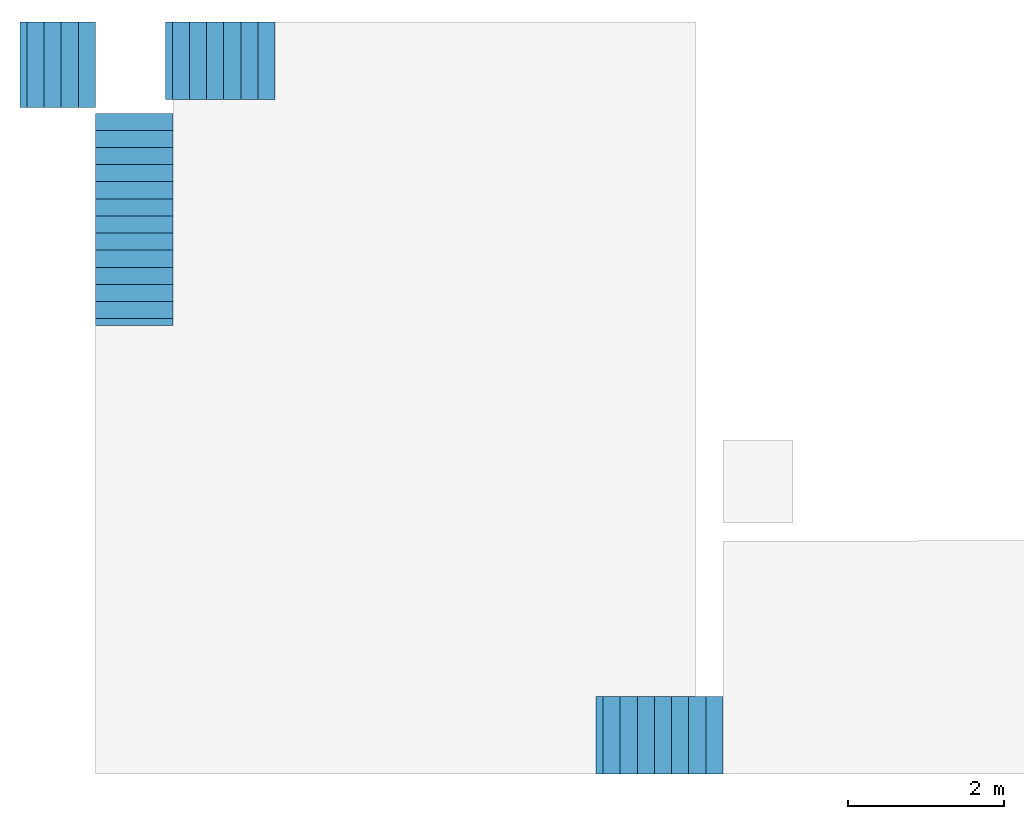
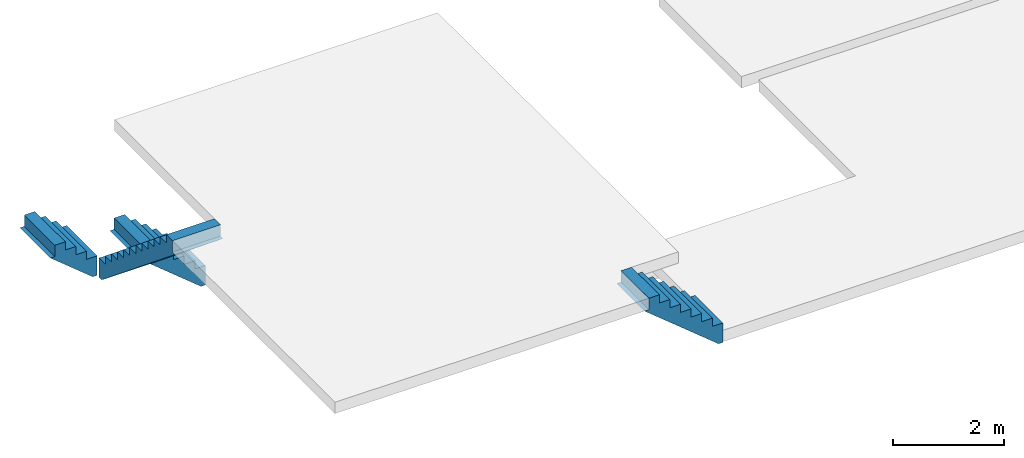
# One storey, part 2 of 2: 4 stair flights.
"""IFC4 building model written with IfcOpenShell, lengths in metres."""

from ifc_helpers import new_model, entity, si_unit, converted_unit, frame, origin_with_axes, origin_2d_with_axis, place, context, subcontext, project, spatial, polygons, type_object, element, save


model = new_model("IFC4")

# Units and contexts
model_context = context("Model", 3, precision=1e-05, world=origin_with_axes())
plan_context = context("Plan", 2, precision=1e-05, world=origin_2d_with_axis())
body_context = subcontext(model_context, "Body", "Model", "MODEL_VIEW")
ifc_project = project(units=[si_unit("VOLUMEUNIT", "CUBIC_METRE"), si_unit("LENGTHUNIT", "METRE"), converted_unit("PLANEANGLEUNIT", "degree", entity("IfcReal", 0.0174532925199433), si_unit("PLANEANGLEUNIT", "RADIAN"), dimensions=[0, 0, 0, 0, 0, 0, 0]), si_unit("AREAUNIT", "SQUARE_METRE")], contexts=[model_context, plan_context])

# Site, building, storey
site_placement = place(None, origin_with_axes())
site = spatial("IfcSite", under=ifc_project, at=site_placement)
building_placement = place(site_placement, origin_with_axes())
building = spatial("IfcBuilding", under=site, at=building_placement)
storey_placement = place(building_placement, frame((0.0, 0.0, 4.23999977111816), z_axis=(0.0, 0.0, 1.0), x_axis=(1.0, 0.0, 0.0)))
storey = spatial("IfcBuildingStorey", under=building, at=storey_placement, Name="First floor")

# Stair flights
stair_flight_type = type_object("IfcStairFlightType", Name="steps", PredefinedType="STRAIGHT")
stair_flight_1_placement = place(storey_placement, frame((21.3532028198242, 13.9787817001343, -2.15999984741211), z_axis=(0.0, 0.0, 1.0), x_axis=(-4.37113882867379e-08, -0.999999999999999, 0.0)))
element("IfcStairFlight", 1, at=stair_flight_1_placement, inside=storey, type_object=stair_flight_type, Name="StairFlight", NumberOfRisers=12, NumberOfTreads=11, PredefinedType="STRAIGHT", RiserHeight=0.180000007152557, TreadLength=0.25, context=body_context, shape_type="Tessellation", body=[
    polygons([(0.0, 0.0, 0.0), (0.0, 0.0, 0.180000007152557), (0.219999998807907, 0.0, 0.180000007152557), (0.219999998807907, 0.0, 0.360000014305115), (0.439999997615814, 0.0, 0.360000014305115), (0.439999997615814, 0.0, 0.540000021457672), (0.659999966621399, 0.0, 0.540000021457672), (0.659999966621399, 0.0, 0.720000028610229), (0.879999995231628, 0.0, 0.720000028610229), (0.879999995231628, 0.0, 0.900000035762787), (1.10000002384186, 0.0, 0.900000035762787), (1.10000002384186, 0.0, 1.08000004291534), (1.3199999332428, 0.0, 1.08000004291534), (1.3199999332428, 0.0, 1.25999999046326), (1.53999996185303, 0.0, 1.25999999046326), (1.53999996185303, 0.0, 1.44000005722046), (1.75999999046326, 0.0, 1.44000005722046), (1.75999999046326, 0.0, 1.62000012397766), (1.98000001907349, 0.0, 1.62000012397766), (1.98000001907349, 0.0, 1.80000007152557), (2.20000004768372, 0.0, 1.80000007152557), (2.20000004768372, 0.0, 1.98000001907349), (2.42000007629395, 0.0, 1.98000001907349), (2.42000007629395, 0.0, 2.16000008583069), (2.6399998664856, 0.0, 2.16000008583069), (2.6399998664856, 0.0, 1.91000008583069), (2.72924065589905, 0.0, 1.91000008583069), (0.0892408341169357, 0.0, -0.25), (0.0, 0.0, -0.25), (0.0, 1.0, 0.180000007152557), (0.219999998807907, 1.0, 0.180000007152557), (0.219999998807907, 1.0, 0.360000014305115), (0.439999997615814, 1.0, 0.360000014305115), (0.439999997615814, 1.0, 0.540000021457672), (0.659999966621399, 1.0, 0.540000021457672), (0.659999966621399, 1.0, 0.720000028610229), (0.879999995231628, 1.0, 0.720000028610229), (0.879999995231628, 1.0, 0.900000035762787), (1.10000002384186, 1.0, 0.900000035762787), (1.10000002384186, 1.0, 1.08000004291534), (1.3199999332428, 1.0, 1.08000004291534), (1.3199999332428, 1.0, 1.25999999046326), (1.53999996185303, 1.0, 1.25999999046326), (1.53999996185303, 1.0, 1.44000005722046), (1.75999999046326, 1.0, 1.44000005722046), (1.75999999046326, 1.0, 1.62000012397766), (1.98000001907349, 1.0, 1.62000012397766), (1.98000001907349, 1.0, 1.80000007152557), (2.20000004768372, 1.0, 1.80000007152557), (2.20000004768372, 1.0, 1.98000001907349), (2.42000007629395, 1.0, 1.98000001907349), (2.42000007629395, 1.0, 2.16000008583069), (2.6399998664856, 1.0, 2.16000008583069), (2.6399998664856, 1.0, 1.91000008583069), (2.72924065589905, 1.0, 1.91000008583069), (0.0892408341169357, 1.0, -0.25), (0.0, 1.0, -0.25), (0.0, 1.0, 0.0)], [[[2, 1, 29, 28, 27, 26, 25, 24, 23, 22, 21, 20, 19, 18, 17, 16, 15, 14, 13, 12, 11, 10, 9, 8, 7, 6, 5, 4, 3]], [[30, 31, 32, 33, 34, 35, 36, 37, 38, 39, 40, 41, 42, 43, 44, 45, 46, 47, 48, 49, 50, 51, 52, 53, 54, 55, 56, 57, 58]], [[5, 6, 34, 33]], [[19, 20, 48, 47]], [[6, 7, 35, 34]], [[20, 21, 49, 48]], [[7, 8, 36, 35]], [[21, 22, 50, 49]], [[8, 9, 37, 36]], [[22, 23, 51, 50]], [[9, 10, 38, 37]], [[23, 24, 52, 51]], [[10, 11, 39, 38]], [[24, 25, 53, 52]], [[11, 12, 40, 39]], [[25, 26, 54, 53]], [[12, 13, 41, 40]], [[26, 27, 55, 54]], [[13, 14, 42, 41]], [[29, 1, 58, 57]], [[14, 15, 43, 42]], [[1, 2, 30, 58]], [[28, 29, 57, 56]], [[15, 16, 44, 43]], [[2, 3, 31, 30]], [[27, 28, 56, 55]], [[16, 17, 45, 44]], [[3, 4, 32, 31]], [[17, 18, 46, 45]], [[4, 5, 33, 32]], [[18, 19, 47, 46]]], closed=True),
])
stair_flight_2_placement = place(storey_placement, frame((23.6632022857666, 15.1537818908691, -3.23999989032745), z_axis=(0.0, 0.0, 1.0), x_axis=(-0.999999999999947, 3.25841369885876e-07, 0.0)))
element("IfcStairFlight", 2, at=stair_flight_2_placement, inside=storey, type_object=stair_flight_type, Name="StairFlight", NumberOfRisers=6, NumberOfTreads=5, PredefinedType="STRAIGHT", RiserHeight=0.180000007152557, TreadLength=0.25, context=body_context, shape_type="Tessellation", body=[
    polygons([(0.0, 0.0, 0.0), (0.0, 0.0, 0.180000007152557), (0.219999998807907, 0.0, 0.180000007152557), (0.219999998807907, 0.0, 0.360000014305115), (0.439999997615814, 0.0, 0.360000014305115), (0.439999997615814, 0.0, 0.540000021457672), (0.659999966621399, 0.0, 0.540000021457672), (0.659999966621399, 0.0, 0.720000028610229), (0.879999995231628, 0.0, 0.720000028610229), (0.879999995231628, 0.0, 0.900000035762787), (1.10000002384186, 0.0, 0.900000035762787), (1.10000002384186, 0.0, 1.08000004291534), (1.3199999332428, 0.0, 1.08000004291534), (1.3199999332428, 0.0, 0.830000042915344), (1.40924072265625, 0.0, 0.830000042915344), (0.0892408341169357, 0.0, -0.25), (0.0, 0.0, -0.25), (0.0, 1.0, 0.180000007152557), (0.219999998807907, 1.0, 0.180000007152557), (0.219999998807907, 1.0, 0.360000014305115), (0.439999997615814, 1.0, 0.360000014305115), (0.439999997615814, 1.0, 0.540000021457672), (0.659999966621399, 1.0, 0.540000021457672), (0.659999966621399, 1.0, 0.720000028610229), (0.879999995231628, 1.0, 0.720000028610229), (0.879999995231628, 1.0, 0.900000035762787), (1.10000002384186, 1.0, 0.900000035762787), (1.10000002384186, 1.0, 1.08000004291534), (1.3199999332428, 1.0, 1.08000004291534), (1.3199999332428, 1.0, 0.830000042915344), (1.40924072265625, 1.0, 0.830000042915344), (0.0892408341169357, 1.0, -0.25), (0.0, 1.0, -0.25), (0.0, 1.0, 0.0)], [[[2, 1, 17, 16, 15, 14, 13, 12, 11, 10, 9, 8, 7, 6, 5, 4, 3]], [[18, 19, 20, 21, 22, 23, 24, 25, 26, 27, 28, 29, 30, 31, 32, 33, 34]], [[1, 2, 18, 34]], [[16, 17, 33, 32]], [[9, 10, 26, 25]], [[2, 3, 19, 18]], [[15, 16, 32, 31]], [[10, 11, 27, 26]], [[3, 4, 20, 19]], [[11, 12, 28, 27]], [[4, 5, 21, 20]], [[12, 13, 29, 28]], [[5, 6, 22, 21]], [[13, 14, 30, 29]], [[6, 7, 23, 22]], [[14, 15, 31, 30]], [[7, 8, 24, 23]], [[17, 1, 34, 33]], [[8, 9, 25, 24]]], closed=True),
])
stair_flight_3_placement = place(storey_placement, frame((21.3532028198242, 15.1537818908691, -2.15999984741211), z_axis=(0.0, 0.0, 1.0), x_axis=(-0.999999999999947, 3.25841369885876e-07, 0.0)))
element("IfcStairFlight", 3, at=stair_flight_3_placement, inside=storey, type_object=stair_flight_type, Name="StairFlight", NumberOfRisers=4, NumberOfTreads=3, PredefinedType="STRAIGHT", RiserHeight=0.180000007152557, TreadLength=0.25, context=body_context, shape_type="Tessellation", body=[
    polygons([(0.0, 0.0, 0.0), (0.0, 0.0, 0.180000007152557), (0.219999998807907, 0.0, 0.180000007152557), (0.219999998807907, 0.0, 0.360000014305115), (0.439999997615814, 0.0, 0.360000014305115), (0.439999997615814, 0.0, 0.540000021457672), (0.659999966621399, 0.0, 0.540000021457672), (0.659999966621399, 0.0, 0.720000028610229), (0.879999995231628, 0.0, 0.720000028610229), (0.879999995231628, 0.0, 0.470000028610229), (0.969240844249725, 0.0, 0.470000028610229), (0.0892408341169357, 0.0, -0.25), (0.0, 0.0, -0.25), (0.0, 1.10000002384186, 0.180000007152557), (0.219999998807907, 1.10000002384186, 0.180000007152557), (0.219999998807907, 1.10000002384186, 0.360000014305115), (0.439999997615814, 1.10000002384186, 0.360000014305115), (0.439999997615814, 1.10000002384186, 0.540000021457672), (0.659999966621399, 1.10000002384186, 0.540000021457672), (0.659999966621399, 1.10000002384186, 0.720000028610229), (0.879999995231628, 1.10000002384186, 0.720000028610229), (0.879999995231628, 1.10000002384186, 0.470000028610229), (0.969240844249725, 1.10000002384186, 0.470000028610229), (0.0892408341169357, 1.10000002384186, -0.25), (0.0, 1.10000002384186, -0.25), (0.0, 1.10000002384186, 0.0)], [[[2, 1, 13, 12, 11, 10, 9, 8, 7, 6, 5, 4, 3]], [[14, 15, 16, 17, 18, 19, 20, 21, 22, 23, 24, 25, 26]], [[2, 3, 15, 14]], [[10, 11, 23, 22]], [[3, 4, 16, 15]], [[13, 1, 26, 25]], [[4, 5, 17, 16]], [[12, 13, 25, 24]], [[5, 6, 18, 17]], [[11, 12, 24, 23]], [[6, 7, 19, 18]], [[7, 8, 20, 19]], [[8, 9, 21, 20]], [[1, 2, 14, 26]], [[9, 10, 22, 21]]], closed=True),
])
stair_flight_4_placement = place(storey_placement, frame((29.4232025146484, 6.4787859916687, -1.25999999046326), z_axis=(0.0, 0.0, 1.0), x_axis=(-0.999999999999947, 3.25841369885876e-07, 0.0)))
element("IfcStairFlight", 4, at=stair_flight_4_placement, inside=storey, type_object=stair_flight_type, Name="StairFlight", NumberOfRisers=7, NumberOfTreads=6, PredefinedType="STRAIGHT", RiserHeight=0.179999998637608, TreadLength=0.25, context=body_context, shape_type="Tessellation", body=[
    polygons([(0.0, 0.0, 0.0), (0.0, 0.0, 0.179999992251396), (0.219999998807907, 0.0, 0.179999992251396), (0.219999998807907, 0.0, 0.359999984502792), (0.439999997615814, 0.0, 0.359999984502792), (0.439999997615814, 0.0, 0.540000021457672), (0.659999966621399, 0.0, 0.540000021457672), (0.659999966621399, 0.0, 0.719999969005585), (0.879999995231628, 0.0, 0.719999969005585), (0.879999995231628, 0.0, 0.899999976158142), (1.10000002384186, 0.0, 0.899999976158142), (1.10000002384186, 0.0, 1.08000004291534), (1.3199999332428, 0.0, 1.08000004291534), (1.3199999332428, 0.0, 1.25999999046326), (1.53999996185303, 0.0, 1.25999999046326), (1.53999996185303, 0.0, 1.00999999046326), (1.62924087047577, 0.0, 1.00999999046326), (0.0892408639192581, 0.0, -0.25), (0.0, 0.0, -0.25), (0.0, 1.0, 0.179999992251396), (0.219999998807907, 1.0, 0.179999992251396), (0.219999998807907, 1.0, 0.359999984502792), (0.439999997615814, 1.0, 0.359999984502792), (0.439999997615814, 1.0, 0.540000021457672), (0.659999966621399, 1.0, 0.540000021457672), (0.659999966621399, 1.0, 0.719999969005585), (0.879999995231628, 1.0, 0.719999969005585), (0.879999995231628, 1.0, 0.899999976158142), (1.10000002384186, 1.0, 0.899999976158142), (1.10000002384186, 1.0, 1.08000004291534), (1.3199999332428, 1.0, 1.08000004291534), (1.3199999332428, 1.0, 1.25999999046326), (1.53999996185303, 1.0, 1.25999999046326), (1.53999996185303, 1.0, 1.00999999046326), (1.62924087047577, 1.0, 1.00999999046326), (0.0892408639192581, 1.0, -0.25), (0.0, 1.0, -0.25), (0.0, 1.0, 0.0)], [[[2, 1, 19, 18, 17, 16, 15, 14, 13, 12, 11, 10, 9, 8, 7, 6, 5, 4, 3]], [[20, 21, 22, 23, 24, 25, 26, 27, 28, 29, 30, 31, 32, 33, 34, 35, 36, 37, 38]], [[15, 16, 34, 33]], [[8, 9, 27, 26]], [[1, 2, 20, 38]], [[16, 17, 35, 34]], [[9, 10, 28, 27]], [[2, 3, 21, 20]], [[19, 1, 38, 37]], [[10, 11, 29, 28]], [[3, 4, 22, 21]], [[18, 19, 37, 36]], [[11, 12, 30, 29]], [[4, 5, 23, 22]], [[17, 18, 36, 35]], [[12, 13, 31, 30]], [[5, 6, 24, 23]], [[13, 14, 32, 31]], [[6, 7, 25, 24]], [[14, 15, 33, 32]], [[7, 8, 26, 25]]], closed=True),
])

save(model, "model.ifc")
